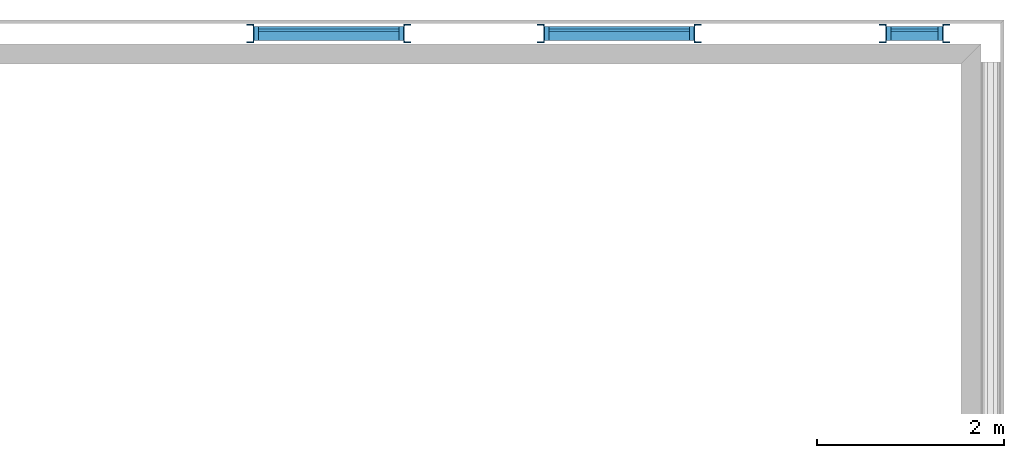
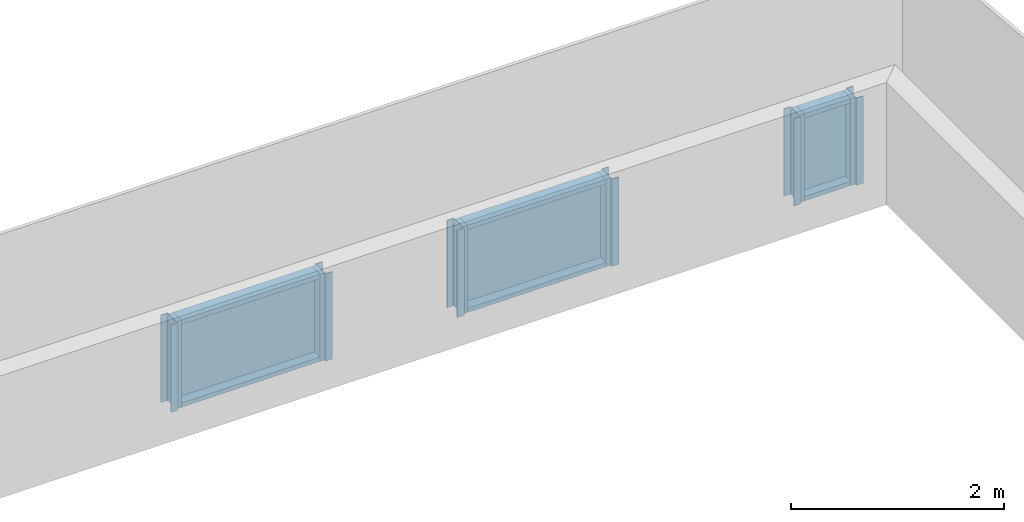
# One storey, part 1 of 4: 12 members, 6 columns, 3 plates, 3 elements without a shape of their own.
"""IFC2X3 building model written with IfcOpenShell, lengths in millimetres."""

from ifc_helpers import new_model, entity, si_unit, converted_unit, money_unit, point, direction, frame, frame_2d, origin_with_axes, origin_2d_with_axis, place, context, subcontext, project, spatial, polyline, circle_curve, parameter, trimmed, segment, composite_curve, rectangle, outline, extrude, material, type_object, element, aggregate, save


model = new_model("IFC2X3")

# Units and contexts
model_context = context("Model", 3, precision=1e-05, world=origin_with_axes(), true_north=direction((0.0, 1.0)))
body_context = subcontext(model_context, "Body", "Model", "MODEL_VIEW")
ifc_project = project(units=[si_unit("LENGTHUNIT", "METRE", prefix="MILLI"), si_unit("AREAUNIT", "SQUARE_METRE"), si_unit("VOLUMEUNIT", "CUBIC_METRE"), converted_unit("PLANEANGLEUNIT", "DEGREE", entity("IfcPlaneAngleMeasure", 0.0174532925199), si_unit("PLANEANGLEUNIT", "RADIAN"), dimensions=[0, 0, 0, 0, 0, 0, 0]), si_unit("SOLIDANGLEUNIT", "STERADIAN"), money_unit("USD"), converted_unit("TIMEUNIT", "Year", entity("IfcTimeMeasure", 31556926.0), si_unit("TIMEUNIT", "SECOND"), dimensions=[0, 0, 0, 0, 0, 0, 0]), si_unit("MASSUNIT", "GRAM"), si_unit("THERMODYNAMICTEMPERATUREUNIT", "DEGREE_CELSIUS"), si_unit("LUMINOUSINTENSITYUNIT", "LUMEN")], contexts=[model_context])

# Site, building, storey
site_placement = place(None, origin_with_axes())
site = spatial("IfcSite", under=ifc_project, at=site_placement, CompositionType="ELEMENT")
building_placement = place(site_placement, origin_with_axes())
building = spatial("IfcBuilding", under=site, at=building_placement, CompositionType="ELEMENT")
storey_placement = place(building_placement, frame((0.0, 0.0, 71700.0), z_axis=(0.0, 0.0, 1.0), x_axis=(1.0, 0.0, 0.0)))
storey = spatial("IfcBuildingStorey", under=building, at=storey_placement, CompositionType="ELEMENT", Elevation=71700.0)

# Columns
ifc_material_1 = material(Name="Metal - Steel 43-275")
column_type_1 = type_object("IfcColumnType", Name="PFC200x75x23", PredefinedType="COLUMN")
for number, where, z_axis, x_axis, name in (
    (1, (8718.47935353, 8402.49616284, 150.0), (0.0, 0.0, 1.0), (0.0, 1.0, 0.0), "PFC-Parallel Flange Channels-Column:PFC200x75x23"),
    (2, (11818.4793532, 8402.49616284, 150.0), (0.0, 0.0, 1.0), (0.0, 1.0, 0.0), "PFC-Parallel Flange Channels-Column:PFC200x75x23"),
    (3, (15468.4793532, 8402.49616284, 150.0), (0.0, 0.0, 1.0), (0.0, 1.0, 0.0), "PFC-Parallel Flange Channels-Column:PFC200x75x23"),
):
    element("IfcColumn", number, at=place(storey_placement, frame(where, z_axis=z_axis, x_axis=x_axis)), inside=storey, type_object=column_type_1, material=ifc_material_1, Name=name, ObjectType="PFC200x75x23", context=body_context, shape_type="SweptSolid", body=[
        extrude(outline(composite_curve([segment(polyline([(-100.0, -34.8), (100.0, -34.8), (100.0, 40.2), (87.5, 40.2), (87.5, -16.8)]), True, "CONTINUOUS"), segment(trimmed(circle_curve(frame_2d((75.5, -16.8), x_axis=(0.0, -1.0)), 12.0), [point((87.5, -16.8)), parameter(90.0)], [point((75.5, -28.8)), parameter(0.0)], False, "CARTESIAN"), True, "CONTINUOUS"), segment(polyline([(75.5, -28.8), (-75.5, -28.8)]), True, "CONTINUOUS"), segment(trimmed(circle_curve(frame_2d((-75.5, -16.8), x_axis=(-1.0, 0.0)), 12.0), [point((-75.5, -28.8)), parameter(90.0)], [point((-87.5, -16.8)), parameter(0.0)], False, "CARTESIAN"), True, "CONTINUOUS"), segment(polyline([(-87.5, -16.8), (-87.5, 40.2), (-100.0, 40.2), (-100.0, -34.8)]), True, "CONTINUOUS")], self_intersect=False)), origin_with_axes(), (0.0, 0.0, 1.0), 1000.0),
    ])
column_type_2 = type_object("IfcColumnType", Name="PFC200x75x23", PredefinedType="COLUMN")
for number, where, z_axis, x_axis, name in (
    (4, (10388.0793535, 8402.49616284, 150.0), (0.0, 0.0, 1.0), (0.0, -1.0, 0.0), "PFC-Parallel Flange Channels-Column:PFC200x75x23"),
    (5, (13488.0793532, 8402.49616284, 150.0), (0.0, 0.0, 1.0), (0.0, -1.0, 0.0), "PFC-Parallel Flange Channels-Column:PFC200x75x23"),
    (6, (16138.0793532, 8402.49616284, 150.0), (0.0, 0.0, 1.0), (0.0, -1.0, 0.0), "PFC-Parallel Flange Channels-Column:PFC200x75x23"),
):
    element("IfcColumn", number, at=place(storey_placement, frame(where, z_axis=z_axis, x_axis=x_axis)), inside=storey, type_object=column_type_2, material=ifc_material_1, Name=name, ObjectType="PFC200x75x23", context=body_context, shape_type="SweptSolid", body=[
        extrude(outline(composite_curve([segment(polyline([(-100.0, -34.8), (100.0, -34.8), (100.0, 40.2), (87.5, 40.2), (87.5, -16.8)]), True, "CONTINUOUS"), segment(trimmed(circle_curve(frame_2d((75.5, -16.8), x_axis=(0.0, -1.0)), 12.0), [point((87.5, -16.8)), parameter(90.0)], [point((75.5, -28.8)), parameter(0.0)], False, "CARTESIAN"), True, "CONTINUOUS"), segment(polyline([(75.5, -28.8), (-75.5, -28.8)]), True, "CONTINUOUS"), segment(trimmed(circle_curve(frame_2d((-75.5, -16.8), x_axis=(-1.0, 0.0)), 12.0), [point((-75.5, -28.8)), parameter(90.0)], [point((-87.5, -16.8)), parameter(0.0)], False, "CARTESIAN"), True, "CONTINUOUS"), segment(polyline([(-87.5, -16.8), (-87.5, 40.2), (-100.0, 40.2), (-100.0, -34.8)]), True, "CONTINUOUS")], self_intersect=False)), origin_with_axes(), (0.0, 0.0, 1.0), 1000.0),
    ])

# Curtain wall, members
curtain_wall_type = type_object("IfcCurtainWallType", Name="Curtain Wall:Curtain_Wall-Storefront", PredefinedType="NOTDEFINED")
curtain_wall_1_placement = place(storey_placement, frame((0.0, 0.0, -71700.0), z_axis=(0.0, 0.0, 1.0), x_axis=(1.0, 0.0, 0.0)))
curtain_wall_1 = element("IfcCurtainWall", 7, at=curtain_wall_1_placement, inside=storey, type_object=curtain_wall_type, Name="Curtain Wall:Curtain_Wall-Storefront", ObjectType="Curtain Wall:Curtain_Wall-Storefront")
ifc_material_2 = material(Name="Background")
member_type = type_object("IfcMemberType", Name="IFC Member Extruded", PredefinedType="NOTDEFINED")
member_1_placement = place(curtain_wall_1_placement, frame((0.0, 0.0, 71700.0), z_axis=(0.0, 0.0, 1.0), x_axis=(1.0, 0.0, 0.0)))
member_1 = element("IfcMember", 8, at=member_1_placement, type_object=member_type, material=ifc_material_2, Name="Curtain Wall:Curtain_Wall-Storefront:8486", ObjectType="Curtain Wall:Curtain_Wall-Storefront:8486", context=body_context, shape_type="SweptSolid", body=[
    extrude(rectangle(XDim=50.0, YDim=150.0, at=origin_2d_with_axis()), frame((11878.2793532, 8402.49616284, 1150.0), z_axis=(0.0, 0.0, -1.0), x_axis=(-1.0, 0.0, 0.0)), (0.0, 0.0, 1.0), 1000.0),
])
member_2_placement = place(curtain_wall_1_placement, frame((0.0, 0.0, 71700.0), z_axis=(0.0, 0.0, 1.0), x_axis=(1.0, 0.0, 0.0)))
member_2 = element("IfcMember", 9, at=member_2_placement, type_object=member_type, material=ifc_material_2, Name="Curtain Wall:Curtain_Wall-Storefront:8486", ObjectType="Curtain Wall:Curtain_Wall-Storefront:8486", context=body_context, shape_type="SweptSolid", body=[
    extrude(rectangle(XDim=50.0, YDim=150.0, at=origin_2d_with_axis()), frame((13403.2793532, 8402.49616284, 1125.0), z_axis=(-1.0, 0.0, 0.0), x_axis=(0.0, 0.0, -1.0)), (0.0, 0.0, 1.0), 1500.0),
])
member_3_placement = place(curtain_wall_1_placement, frame((0.0, 0.0, 71700.0), z_axis=(0.0, 0.0, 1.0), x_axis=(1.0, 0.0, 0.0)))
member_3 = element("IfcMember", 10, at=member_3_placement, type_object=member_type, material=ifc_material_2, Name="Curtain Wall:Curtain_Wall-Storefront:8486", ObjectType="Curtain Wall:Curtain_Wall-Storefront:8486", context=body_context, shape_type="SweptSolid", body=[
    extrude(rectangle(XDim=50.0, YDim=150.0, at=origin_2d_with_axis()), frame((13428.2793532, 8402.49616284, 150.0), z_axis=(0.0, 0.0, 1.0), x_axis=(-1.0, 0.0, 0.0)), (0.0, 0.0, 1.0), 1000.0),
])
member_4_placement = place(curtain_wall_1_placement, frame((0.0, 0.0, 71700.0), z_axis=(0.0, 0.0, 1.0), x_axis=(1.0, 0.0, 0.0)))
member_4 = element("IfcMember", 11, at=member_4_placement, type_object=member_type, material=ifc_material_2, Name="Curtain Wall:Curtain_Wall-Storefront:8486", ObjectType="Curtain Wall:Curtain_Wall-Storefront:8486", context=body_context, shape_type="SweptSolid", body=[
    extrude(rectangle(XDim=50.0, YDim=150.0, at=origin_2d_with_axis()), frame((11903.2793532, 8402.49616284, 175.0), z_axis=(1.0, 0.0, 0.0), x_axis=(0.0, 0.0, -1.0)), (0.0, 0.0, 1.0), 1500.0),
])

curtain_wall_2_placement = place(storey_placement, frame((0.0, 0.0, -71700.0), z_axis=(0.0, 0.0, 1.0), x_axis=(1.0, 0.0, 0.0)))
curtain_wall_2 = element("IfcCurtainWall", 12, at=curtain_wall_2_placement, inside=storey, type_object=curtain_wall_type, Name="Curtain Wall:Curtain_Wall-Storefront", ObjectType="Curtain Wall:Curtain_Wall-Storefront")
member_5_placement = place(curtain_wall_2_placement, frame((0.0, 0.0, 71700.0), z_axis=(0.0, 0.0, 1.0), x_axis=(1.0, 0.0, 0.0)))
member_5 = element("IfcMember", 13, at=member_5_placement, type_object=member_type, material=ifc_material_2, Name="Curtain Wall:Curtain_Wall-Storefront:8486", ObjectType="Curtain Wall:Curtain_Wall-Storefront:8486", context=body_context, shape_type="SweptSolid", body=[
    extrude(rectangle(XDim=50.0, YDim=150.0, at=origin_2d_with_axis()), frame((8778.27935353, 8402.49616284, 1150.0), z_axis=(0.0, 0.0, -1.0), x_axis=(-1.0, 0.0, 0.0)), (0.0, 0.0, 1.0), 1000.0),
])
member_6_placement = place(curtain_wall_2_placement, frame((0.0, 0.0, 71700.0), z_axis=(0.0, 0.0, 1.0), x_axis=(1.0, 0.0, 0.0)))
member_6 = element("IfcMember", 14, at=member_6_placement, type_object=member_type, material=ifc_material_2, Name="Curtain Wall:Curtain_Wall-Storefront:8486", ObjectType="Curtain Wall:Curtain_Wall-Storefront:8486", context=body_context, shape_type="SweptSolid", body=[
    extrude(rectangle(XDim=50.0, YDim=150.0, at=origin_2d_with_axis()), frame((10303.2793535, 8402.49616284, 1125.0), z_axis=(-1.0, 0.0, 0.0), x_axis=(0.0, 0.0, -1.0)), (0.0, 0.0, 1.0), 1500.0),
])
member_7_placement = place(curtain_wall_2_placement, frame((0.0, 0.0, 71700.0), z_axis=(0.0, 0.0, 1.0), x_axis=(1.0, 0.0, 0.0)))
member_7 = element("IfcMember", 15, at=member_7_placement, type_object=member_type, material=ifc_material_2, Name="Curtain Wall:Curtain_Wall-Storefront:8486", ObjectType="Curtain Wall:Curtain_Wall-Storefront:8486", context=body_context, shape_type="SweptSolid", body=[
    extrude(rectangle(XDim=50.0, YDim=150.0, at=origin_2d_with_axis()), frame((10328.2793535, 8402.49616284, 150.0), z_axis=(0.0, 0.0, 1.0), x_axis=(-1.0, 0.0, 0.0)), (0.0, 0.0, 1.0), 1000.0),
])
member_8_placement = place(curtain_wall_2_placement, frame((0.0, 0.0, 71700.0), z_axis=(0.0, 0.0, 1.0), x_axis=(1.0, 0.0, 0.0)))
member_8 = element("IfcMember", 16, at=member_8_placement, type_object=member_type, material=ifc_material_2, Name="Curtain Wall:Curtain_Wall-Storefront:8486", ObjectType="Curtain Wall:Curtain_Wall-Storefront:8486", context=body_context, shape_type="SweptSolid", body=[
    extrude(rectangle(XDim=50.0, YDim=150.0, at=origin_2d_with_axis()), frame((8803.27935353, 8402.49616284, 175.0), z_axis=(1.0, 0.0, 0.0), x_axis=(0.0, 0.0, -1.0)), (0.0, 0.0, 1.0), 1500.0),
])

curtain_wall_3_placement = place(storey_placement, frame((0.0, 0.0, -71700.0), z_axis=(0.0, 0.0, 1.0), x_axis=(1.0, 0.0, 0.0)))
curtain_wall_3 = element("IfcCurtainWall", 17, at=curtain_wall_3_placement, inside=storey, type_object=curtain_wall_type, Name="Curtain Wall:Curtain_Wall-Storefront", ObjectType="Curtain Wall:Curtain_Wall-Storefront")
member_9_placement = place(curtain_wall_3_placement, frame((0.0, 0.0, 71700.0), z_axis=(0.0, 0.0, 1.0), x_axis=(1.0, 0.0, 0.0)))
member_9 = element("IfcMember", 18, at=member_9_placement, type_object=member_type, material=ifc_material_2, Name="Curtain Wall:Curtain_Wall-Storefront:8486", ObjectType="Curtain Wall:Curtain_Wall-Storefront:8486", context=body_context, shape_type="SweptSolid", body=[
    extrude(rectangle(XDim=50.0, YDim=150.0, at=origin_2d_with_axis()), frame((15528.2793532, 8402.49616284, 1150.0), z_axis=(0.0, 0.0, -1.0), x_axis=(-1.0, 0.0, 0.0)), (0.0, 0.0, 1.0), 1000.0),
])
member_10_placement = place(curtain_wall_3_placement, frame((0.0, 0.0, 71700.0), z_axis=(0.0, 0.0, 1.0), x_axis=(1.0, 0.0, 0.0)))
member_10 = element("IfcMember", 19, at=member_10_placement, type_object=member_type, material=ifc_material_2, Name="Curtain Wall:Curtain_Wall-Storefront:8486", ObjectType="Curtain Wall:Curtain_Wall-Storefront:8486", context=body_context, shape_type="SweptSolid", body=[
    extrude(rectangle(XDim=50.0, YDim=150.0, at=origin_2d_with_axis()), frame((16053.2793532, 8402.49616284, 1125.0), z_axis=(-1.0, 0.0, 0.0), x_axis=(0.0, 0.0, -1.0)), (0.0, 0.0, 1.0), 500.0),
])
member_11_placement = place(curtain_wall_3_placement, frame((0.0, 0.0, 71700.0), z_axis=(0.0, 0.0, 1.0), x_axis=(1.0, 0.0, 0.0)))
member_11 = element("IfcMember", 20, at=member_11_placement, type_object=member_type, material=ifc_material_2, Name="Curtain Wall:Curtain_Wall-Storefront:8486", ObjectType="Curtain Wall:Curtain_Wall-Storefront:8486", context=body_context, shape_type="SweptSolid", body=[
    extrude(rectangle(XDim=50.0, YDim=150.0, at=origin_2d_with_axis()), frame((16078.2793532, 8402.49616284, 150.0), z_axis=(0.0, 0.0, 1.0), x_axis=(-1.0, 0.0, 0.0)), (0.0, 0.0, 1.0), 1000.0),
])
member_12_placement = place(curtain_wall_3_placement, frame((0.0, 0.0, 71700.0), z_axis=(0.0, 0.0, 1.0), x_axis=(1.0, 0.0, 0.0)))
member_12 = element("IfcMember", 21, at=member_12_placement, type_object=member_type, material=ifc_material_2, Name="Curtain Wall:Curtain_Wall-Storefront:8486", ObjectType="Curtain Wall:Curtain_Wall-Storefront:8486", context=body_context, shape_type="SweptSolid", body=[
    extrude(rectangle(XDim=50.0, YDim=150.0, at=origin_2d_with_axis()), frame((15553.2793532, 8402.49616284, 175.0), z_axis=(1.0, 0.0, 0.0), x_axis=(0.0, 0.0, -1.0)), (0.0, 0.0, 1.0), 500.0),
])

# Plate
plate_type_1 = type_object("IfcPlateType", Name="Glazed", PredefinedType="CURTAIN_PANEL")
plate_1_placement = place(curtain_wall_1_placement, frame((11903.2793532, 8426.99616284, 71900.0), z_axis=(0.0, 0.0, 1.0), x_axis=(1.0, 0.0, 0.0)))
plate_1 = element("IfcPlate", 22, at=plate_1_placement, type_object=plate_type_1, material=ifc_material_2, Name="System Panel:Glazed", ObjectType="Glazed", context=body_context, shape_type="SweptSolid", body=[
    extrude(rectangle(XDim=25.0, YDim=1500.0, at=origin_2d_with_axis()), frame((750.0, 12.5, 0.0), z_axis=(0.0, 0.0, 1.0), x_axis=(0.0, 1.0, 0.0)), (0.0, 0.0, 1.0), 900.0),
])

aggregate(curtain_wall_1, [plate_1, member_1, member_2, member_3, member_4])

plate_2_placement = place(curtain_wall_2_placement, frame((8803.27935353, 8426.99616284, 71900.0), z_axis=(0.0, 0.0, 1.0), x_axis=(1.0, 0.0, 0.0)))
plate_2 = element("IfcPlate", 23, at=plate_2_placement, type_object=plate_type_1, material=ifc_material_2, Name="System Panel:Glazed", ObjectType="Glazed", context=body_context, shape_type="SweptSolid", body=[
    extrude(rectangle(XDim=25.0, YDim=1500.0, at=origin_2d_with_axis()), frame((750.0, 12.5, 0.0), z_axis=(0.0, 0.0, 1.0), x_axis=(0.0, 1.0, 0.0)), (0.0, 0.0, 1.0), 900.0),
])

aggregate(curtain_wall_2, [plate_2, member_5, member_6, member_7, member_8])

plate_type_2 = type_object("IfcPlateType", Name="Glazed", PredefinedType="CURTAIN_PANEL")
plate_3_placement = place(curtain_wall_3_placement, frame((15553.2793532, 8426.99616284, 71900.0), z_axis=(0.0, 0.0, 1.0), x_axis=(1.0, 0.0, 0.0)))
plate_3 = element("IfcPlate", 24, at=plate_3_placement, type_object=plate_type_2, material=ifc_material_2, Name="System Panel:Glazed", ObjectType="Glazed", context=body_context, shape_type="SweptSolid", body=[
    extrude(rectangle(XDim=25.0, YDim=500.0, at=origin_2d_with_axis()), frame((250.0, 12.5, 0.0), z_axis=(0.0, 0.0, 1.0), x_axis=(0.0, 1.0, 0.0)), (0.0, 0.0, 1.0), 900.0),
])

aggregate(curtain_wall_3, [plate_3, member_9, member_10, member_11, member_12])

save(model, "model.ifc")
